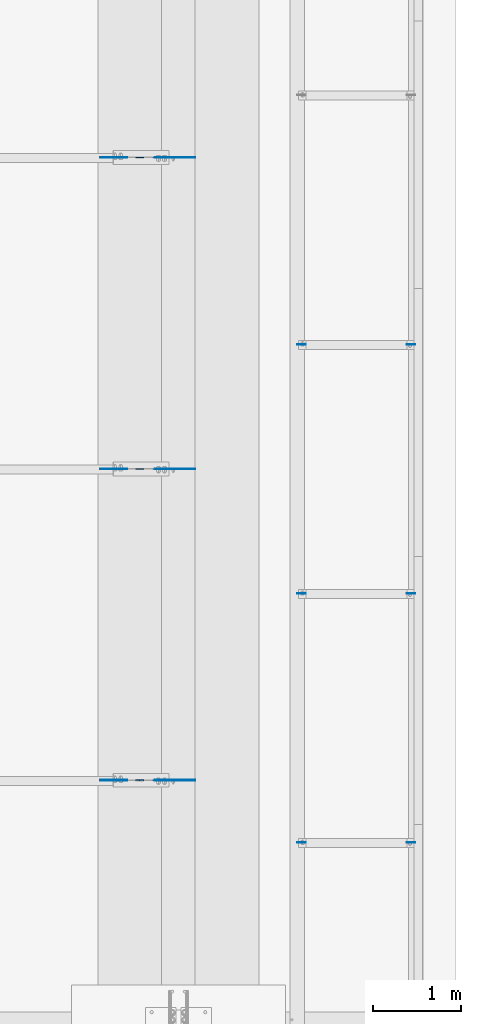
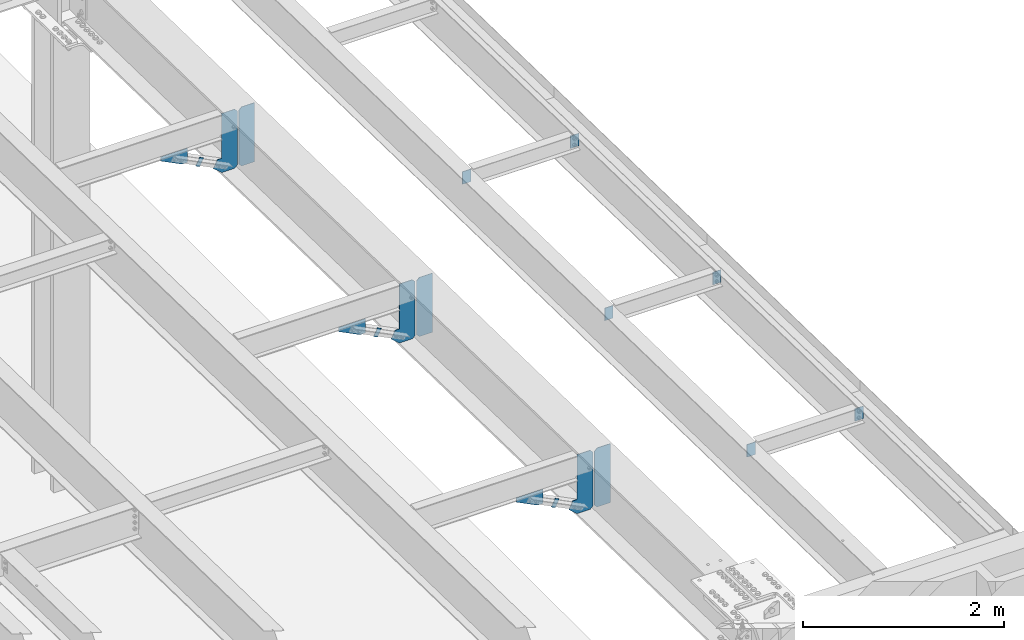
# One storey, part 1569 of 1763: 18 plates, 9 elements without a shape of their own.
"""IFC2X3 building model written with IfcOpenShell, lengths in millimetres."""

from ifc_helpers import new_model, si_unit, frame, origin_with_axes, place, context, subcontext, project, spatial, faceted_brep, material, type_object, element, aggregate, save


model = new_model("IFC2X3")

# Units and contexts
model_context = context("Model", 3, precision=1e-05, world=origin_with_axes())
body_context = subcontext(model_context, "Body", "Model", "MODEL_VIEW")
ifc_project = project(units=[si_unit("LENGTHUNIT", "METRE", prefix="MILLI"), si_unit("AREAUNIT", "SQUARE_METRE"), si_unit("VOLUMEUNIT", "CUBIC_METRE"), si_unit("MASSUNIT", "GRAM", prefix="KILO"), si_unit("TIMEUNIT", "SECOND"), si_unit("PLANEANGLEUNIT", "RADIAN"), si_unit("SOLIDANGLEUNIT", "STERADIAN"), si_unit("THERMODYNAMICTEMPERATUREUNIT", "DEGREE_CELSIUS"), si_unit("LUMINOUSINTENSITYUNIT", "LUMEN")], contexts=[model_context])

# Site, building, storey
site_placement = place(None, origin_with_axes())
site = spatial("IfcSite", under=ifc_project, at=site_placement, CompositionType="ELEMENT")
building_placement = place(site_placement, origin_with_axes())
building = spatial("IfcBuilding", under=site, at=building_placement, Name="Undefined", CompositionType="ELEMENT")
storey_placement = place(building_placement, origin_with_axes())
storey = spatial("IfcBuildingStorey", under=building, at=storey_placement, Name="Undefined", CompositionType="ELEMENT", Elevation=0.0)

# Assembly, plate
assembly_1_placement = place(storey_placement, origin_with_axes())
assembly_1 = element("IfcElementAssembly", 1, at=assembly_1_placement, inside=storey, Name="BEAM", AssemblyPlace="NOTDEFINED", PredefinedType="RIGID_FRAME")
ifc_material = material(Name="STEEL/A36")
plate_type_1 = type_object("IfcPlateType", PredefinedType="NOTDEFINED")
plate_1_placement = place(assembly_1_placement, frame((-24423.7585815478, -3079.7607496631, 11487.5607302139), z_axis=(-0.894427191199916, 0.0, 0.447213595099958), x_axis=(-0.447213595099945, 0.0, -0.894427191199922)))
plate_1 = element("IfcPlate", 2, at=plate_1_placement, type_object=plate_type_1, material=ifc_material, Name="PLATE", context=body_context, shape_type="Brep", body=[
    faceted_brep([(1.81898940354586e-12, -3.17500000000291, 0.0), (0.0, -3.17500000000291, 50.7999992370605), (0.0, 3.17500000000291, 50.7999992370605), (-1.81898940354586e-12, 3.17499999997381, 0.0), (101.599998474121, -3.17500000000291, 50.7999992370605), (101.599998474121, 3.17500000000291, 50.7999992370605), (101.599990844785, -3.17499999999927, -1.81898940354586e-11), (101.599990844785, 3.17499999999927, -1.81898940354586e-11)], [[[0, 1, 2, 3]], [[1, 4, 5, 2]], [[4, 6, 7, 5]], [[6, 0, 3, 7]], [[5, 7, 3, 2]], [[6, 4, 1, 0]]]),
])
aggregate(assembly_1, [plate_1])

assembly_2_placement = place(storey_placement, origin_with_axes())
assembly_2 = element("IfcElementAssembly", 3, at=assembly_2_placement, inside=storey, Name="BEAM", AssemblyPlace="NOTDEFINED", PredefinedType="RIGID_FRAME")
plate_2_placement = place(assembly_2_placement, frame((-24423.7585815478, -6623.04997034739, 11561.6364619885), z_axis=(-0.894427191199916, 0.0, 0.447213595099958), x_axis=(-0.447213595099945, 0.0, -0.894427191199922)))
plate_2 = element("IfcPlate", 4, at=plate_2_placement, type_object=plate_type_1, material=ifc_material, Name="PLATE", context=body_context, shape_type="Brep", body=[
    faceted_brep([(1.81898940354586e-12, -3.17500000000291, 0.0), (0.0, -3.17500000000291, 50.7999992370605), (0.0, 3.17500000000291, 50.7999992370605), (-1.81898940354586e-12, 3.17499999997381, 0.0), (101.599998474121, -3.17500000000291, 50.7999992370605), (101.599998474121, 3.17500000000291, 50.7999992370605), (101.599990844785, -3.17499999999927, -1.81898940354586e-11), (101.599990844785, 3.17499999999927, -1.81898940354586e-11)], [[[0, 1, 2, 3]], [[1, 4, 5, 2]], [[4, 6, 7, 5]], [[6, 0, 3, 7]], [[5, 7, 3, 2]], [[6, 4, 1, 0]]]),
])
aggregate(assembly_2, [plate_2])

assembly_3_placement = place(storey_placement, origin_with_axes())
assembly_3 = element("IfcElementAssembly", 5, at=assembly_3_placement, inside=storey, Name="BEAM", AssemblyPlace="NOTDEFINED", PredefinedType="RIGID_FRAME")
plate_3_placement = place(assembly_3_placement, frame((-24423.7585815478, -10166.3500000141, 11635.7124197349), z_axis=(-0.894427191199916, 0.0, 0.447213595099958), x_axis=(-0.447213595099945, 0.0, -0.894427191199922)))
plate_3 = element("IfcPlate", 6, at=plate_3_placement, type_object=plate_type_1, material=ifc_material, Name="PLATE", context=body_context, shape_type="Brep", body=[
    faceted_brep([(1.81898940354586e-12, -3.17500000000291, 0.0), (0.0, -3.17500000000291, 50.7999992370605), (0.0, 3.17500000000291, 50.7999992370605), (-1.81898940354586e-12, 3.17499999997381, 0.0), (101.599998474121, -3.17500000000291, 50.7999992370605), (101.599998474121, 3.17500000000291, 50.7999992370605), (101.599990844785, -3.17499999999927, -1.81898940354586e-11), (101.599990844785, 3.17499999999927, -1.81898940354586e-11)], [[[0, 1, 2, 3]], [[1, 4, 5, 2]], [[4, 6, 7, 5]], [[6, 0, 3, 7]], [[5, 7, 3, 2]], [[6, 4, 1, 0]]]),
])
aggregate(assembly_3, [plate_3])

assembly_4_placement = place(storey_placement, origin_with_axes())
assembly_4 = element("IfcElementAssembly", 7, at=assembly_4_placement, inside=storey, Name="BEAM", AssemblyPlace="NOTDEFINED", PredefinedType="RIGID_FRAME")
plate_type_2 = type_object("IfcPlateType", PredefinedType="NOTDEFINED")
plate_4_placement = place(assembly_4_placement, frame((-21333.8497736984, -5206.52374998633, 11995.1677041314), z_axis=(-1.0, 0.0, 0.0), x_axis=(0.0, 0.0, -1.0)))
plate_4 = element("IfcPlate", 8, at=plate_4_placement, type_object=plate_type_2, material=ifc_material, Name="PLATE", context=body_context, shape_type="Brep", body=[
    faceted_brep([(1.81898940354586e-12, -3.17500000000291, 0.0), (0.0, -3.17499999999927, 96.8375015258789), (0.0, 3.17499999999927, 96.8375015258789), (-1.81898940354586e-12, 3.17499999997381, 0.0), (152.399993896484, -3.17499999999927, 96.8375015258789), (152.399993896484, 3.17499999999927, 96.8375015258789), (152.399993896484, -3.17500000000291, 0.0), (152.399993896484, 3.17500000000291, 0.0)], [[[0, 1, 2, 3]], [[1, 4, 5, 2]], [[4, 6, 7, 5]], [[6, 0, 3, 7]], [[5, 7, 3, 2]], [[6, 4, 1, 0]]]),
])

assembly_5_placement = place(storey_placement, origin_with_axes())
assembly_5 = element("IfcElementAssembly", 9, at=assembly_5_placement, inside=storey, Name="BEAM", AssemblyPlace="NOTDEFINED", PredefinedType="RIGID_FRAME")
plate_5_placement = place(assembly_5_placement, frame((-22673.6997736984, -5206.52374998633, 11995.1677041314), z_axis=(1.0, 0.0, 0.0), x_axis=(0.0, 0.0, -1.0)))
plate_5 = element("IfcPlate", 10, at=plate_5_placement, type_object=plate_type_2, material=ifc_material, Name="PLATE", context=body_context, shape_type="Brep", body=[
    faceted_brep([(1.81898940354586e-12, -3.17500000000291, 0.0), (0.0, -3.17499999999927, 96.8375015258789), (0.0, 3.17499999999927, 96.8375015258789), (-1.81898940354586e-12, 3.17499999997381, 0.0), (152.399993896484, -3.17499999999927, 96.8375015258789), (152.399993896484, 3.17499999999927, 96.8375015258789), (152.399993896484, -3.17500000000291, 0.0), (152.399993896484, 3.17500000000291, 0.0)], [[[0, 1, 2, 3]], [[1, 4, 5, 2]], [[4, 6, 7, 5]], [[6, 0, 3, 7]], [[5, 7, 3, 2]], [[6, 4, 1, 0]]]),
])

# Plate
plate_6_placement = place(assembly_4_placement, frame((-21333.8497736984, -8041.16374999085, 12054.4284698343), z_axis=(-1.0, 0.0, 0.0), x_axis=(0.0, 0.0, -1.0)))
plate_6 = element("IfcPlate", 11, at=plate_6_placement, type_object=plate_type_2, material=ifc_material, Name="PLATE", context=body_context, shape_type="Brep", body=[
    faceted_brep([(1.81898940354586e-12, -3.17500000000291, 0.0), (0.0, -3.17499999999927, 96.8375015258789), (0.0, 3.17499999999927, 96.8375015258789), (-1.81898940354586e-12, 3.17499999997381, 0.0), (152.399993896484, -3.17499999999927, 96.8375015258789), (152.399993896484, 3.17499999999927, 96.8375015258789), (152.399993896484, -3.17500000000291, 0.0), (152.399993896484, 3.17500000000291, 0.0)], [[[0, 1, 2, 3]], [[1, 4, 5, 2]], [[4, 6, 7, 5]], [[6, 0, 3, 7]], [[5, 7, 3, 2]], [[6, 4, 1, 0]]]),
])

plate_7_placement = place(assembly_5_placement, frame((-22673.6997736984, -8041.16374999085, 12054.4284698343), z_axis=(1.0, 0.0, 0.0), x_axis=(0.0, 0.0, -1.0)))
plate_7 = element("IfcPlate", 12, at=plate_7_placement, type_object=plate_type_2, material=ifc_material, Name="PLATE", context=body_context, shape_type="Brep", body=[
    faceted_brep([(1.81898940354586e-12, -3.17500000000291, 0.0), (0.0, -3.17499999999927, 96.8375015258789), (0.0, 3.17499999999927, 96.8375015258789), (-1.81898940354586e-12, 3.17499999997381, 0.0), (152.399993896484, -3.17499999999927, 96.8375015258789), (152.399993896484, 3.17499999999927, 96.8375015258789), (152.399993896484, -3.17500000000291, 0.0), (152.399993896484, 3.17500000000291, 0.0)], [[[0, 1, 2, 3]], [[1, 4, 5, 2]], [[4, 6, 7, 5]], [[6, 0, 3, 7]], [[5, 7, 3, 2]], [[6, 4, 1, 0]]]),
])

plate_8_placement = place(assembly_4_placement, frame((-21333.8497736984, -10875.8037499954, 12113.6892355372), z_axis=(-1.0, 0.0, 0.0), x_axis=(0.0, 0.0, -1.0)))
plate_8 = element("IfcPlate", 13, at=plate_8_placement, type_object=plate_type_2, material=ifc_material, Name="PLATE", context=body_context, shape_type="Brep", body=[
    faceted_brep([(1.81898940354586e-12, -3.17500000000291, 0.0), (0.0, -3.17499999999927, 96.8375015258789), (0.0, 3.17499999999927, 96.8375015258789), (-1.81898940354586e-12, 3.17499999997381, 0.0), (152.399993896484, -3.17499999999927, 96.8375015258789), (152.399993896484, 3.17499999999927, 96.8375015258789), (152.399993896484, -3.17500000000291, 0.0), (152.399993896484, 3.17500000000291, 0.0)], [[[0, 1, 2, 3]], [[1, 4, 5, 2]], [[4, 6, 7, 5]], [[6, 0, 3, 7]], [[5, 7, 3, 2]], [[6, 4, 1, 0]]]),
])

aggregate(assembly_4, [plate_4, plate_6, plate_8])

plate_9_placement = place(assembly_5_placement, frame((-22673.6997736984, -10875.8037499954, 12113.6892355372), z_axis=(1.0, 0.0, 0.0), x_axis=(0.0, 0.0, -1.0)))
plate_9 = element("IfcPlate", 14, at=plate_9_placement, type_object=plate_type_2, material=ifc_material, Name="PLATE", context=body_context, shape_type="Brep", body=[
    faceted_brep([(1.81898940354586e-12, -3.17500000000291, 0.0), (0.0, -3.17499999999927, 96.8375015258789), (0.0, 3.17499999999927, 96.8375015258789), (-1.81898940354586e-12, 3.17499999997381, 0.0), (152.399993896484, -3.17499999999927, 96.8375015258789), (152.399993896484, 3.17499999999927, 96.8375015258789), (152.399993896484, -3.17500000000291, 0.0), (152.399993896484, 3.17500000000291, 0.0)], [[[0, 1, 2, 3]], [[1, 4, 5, 2]], [[4, 6, 7, 5]], [[6, 0, 3, 7]], [[5, 7, 3, 2]], [[6, 4, 1, 0]]]),
])

aggregate(assembly_5, [plate_5, plate_7, plate_9])

# Assembly, plates
assembly_6_placement = place(storey_placement, origin_with_axes())
assembly_6 = element("IfcElementAssembly", 15, at=assembly_6_placement, inside=storey, Name="BEAM", AssemblyPlace="NOTDEFINED", PredefinedType="RIGID_FRAME")
plate_type_3 = type_object("IfcPlateType", PredefinedType="NOTDEFINED")
plate_10_placement = place(assembly_6_placement, frame((-24019.5997736984, -3079.76074969909, 11236.4175994145), z_axis=(0.0, 0.0, 1.0), x_axis=(1.0, 0.0, 0.0)))
plate_10 = element("IfcPlate", 16, at=plate_10_placement, type_object=plate_type_3, material=ifc_material, Name="PLATE", context=body_context, shape_type="Brep", body=[
    faceted_brep([(0.0, -3.17500000000291, 31.75), (0.0, -3.17499999999927, 686.812194824219), (0.0, 3.17499999999927, 686.812194824219), (0.0, 3.17500000000291, 31.75), (31.75, -3.17499999999927, 718.562194824219), (31.75, 3.17499999999927, 718.562194824219), (182.5625, -3.17499999999927, 718.562194824219), (182.5625, 3.17499999999927, 718.562194824219), (182.5625, -3.17500000000291, 0.0), (182.5625, 3.17500000000291, 0.0), (31.7499999999036, -3.17499999997381, 9.42916855706244e-11), (31.7499999998854, 3.17500000000291, 9.42916855706244e-11)], [[[0, 1, 2, 3]], [[1, 4, 5, 2]], [[4, 6, 7, 5]], [[6, 8, 9, 7]], [[8, 10, 11, 9]], [[10, 0, 3, 11]], [[5, 7, 9, 11, 3, 2]], [[10, 8, 6, 4, 1, 0]]]),
])
plate_11_placement = place(assembly_6_placement, frame((-24019.5997736984, -6623.04997038337, 11310.4933311891), z_axis=(0.0, 0.0, 1.0), x_axis=(1.0, 0.0, 0.0)))
plate_11 = element("IfcPlate", 17, at=plate_11_placement, type_object=plate_type_3, material=ifc_material, Name="PLATE", context=body_context, shape_type="Brep", body=[
    faceted_brep([(0.0, -3.17500000000291, 31.75), (0.0, -3.17499999999927, 686.812194824219), (0.0, 3.17499999999927, 686.812194824219), (0.0, 3.17500000000291, 31.75), (31.75, -3.17499999999927, 718.562194824219), (31.75, 3.17499999999927, 718.562194824219), (182.5625, -3.17499999999927, 718.562194824219), (182.5625, 3.17499999999927, 718.562194824219), (182.5625, -3.17500000000291, 0.0), (182.5625, 3.17500000000291, 0.0), (31.7499999999036, -3.17499999997381, 9.42916855706244e-11), (31.7499999998854, 3.17500000000291, 9.42916855706244e-11)], [[[0, 1, 2, 3]], [[1, 4, 5, 2]], [[4, 6, 7, 5]], [[6, 8, 9, 7]], [[8, 10, 11, 9]], [[10, 0, 3, 11]], [[5, 7, 9, 11, 3, 2]], [[10, 8, 6, 4, 1, 0]]]),
])
plate_12_placement = place(assembly_6_placement, frame((-24019.5997736984, -10166.3500000501, 11384.5692889355), z_axis=(0.0, 0.0, 1.0), x_axis=(1.0, 0.0, 0.0)))
plate_12 = element("IfcPlate", 18, at=plate_12_placement, type_object=plate_type_3, material=ifc_material, Name="PLATE", context=body_context, shape_type="Brep", body=[
    faceted_brep([(0.0, -3.17500000000291, 31.75), (0.0, -3.17499999999927, 686.812194824219), (0.0, 3.17499999999927, 686.812194824219), (0.0, 3.17500000000291, 31.75), (31.75, -3.17499999999927, 718.562194824219), (31.75, 3.17499999999927, 718.562194824219), (182.5625, -3.17499999999927, 718.562194824219), (182.5625, 3.17499999999927, 718.562194824219), (182.5625, -3.17500000000291, 0.0), (182.5625, 3.17500000000291, 0.0), (31.7499999999036, -3.17499999997381, 9.42916855706244e-11), (31.7499999998854, 3.17500000000291, 9.42916855706244e-11)], [[[0, 1, 2, 3]], [[1, 4, 5, 2]], [[4, 6, 7, 5]], [[6, 8, 9, 7]], [[8, 10, 11, 9]], [[10, 0, 3, 11]], [[5, 7, 9, 11, 3, 2]], [[10, 8, 6, 4, 1, 0]]]),
])
plate_type_4 = type_object("IfcPlateType", PredefinedType="NOTDEFINED")
plate_13_placement = place(assembly_6_placement, frame((-24036.0747736984, -3079.76074969909, 11236.4175994145), z_axis=(0.0, 0.0, 1.0), x_axis=(-1.0, 0.0, 0.0)))
plate_13 = element("IfcPlate", 19, at=plate_13_placement, type_object=plate_type_4, material=ifc_material, Name="PLATE", context=body_context, shape_type="Brep", body=[
    faceted_brep([(0.0, -3.17500000000291, 31.75), (0.0, -3.17499999999927, 686.812255859375), (0.0, 3.17499999999927, 686.812255859375), (0.0, 3.17500000000291, 31.75), (31.75, -3.17499999999927, 718.562255859375), (31.75, 3.17499999999927, 718.562255859375), (182.261993408203, -3.17499999999927, 718.562255859375), (182.261993408203, 3.17499999999927, 718.562255859375), (182.261993408203, -3.17499999999927, 172.454345703125), (182.261993408203, 3.17499999999927, 172.454345703125), (230.306228637695, -3.17499999999927, 172.454345703125), (230.306228637695, 3.17499999999927, 172.454345703125), (275.743133544922, -3.17499999999927, 81.5805358886719), (275.743133544922, 3.17499999999927, 81.5805358886719), (182.261993408203, -3.17499999999927, 0.0), (182.261993408203, 3.17499999999927, 0.0), (31.7499999999036, -3.17499999997381, 9.42916855706244e-11), (31.7499999998854, 3.17500000000291, 9.42916855706244e-11)], [[[0, 1, 2, 3]], [[1, 4, 5, 2]], [[4, 6, 7, 5]], [[6, 8, 9, 7]], [[8, 10, 11, 9]], [[10, 12, 13, 11]], [[12, 14, 15, 13]], [[14, 16, 17, 15]], [[16, 0, 3, 17]], [[5, 7, 9, 11, 13, 15, 17, 3, 2]], [[16, 14, 12, 10, 8, 6, 4, 1, 0]]]),
])
plate_14_placement = place(assembly_6_placement, frame((-24036.0747736984, -6623.04997038337, 11310.4933311891), z_axis=(0.0, 0.0, 1.0), x_axis=(-1.0, 0.0, 0.0)))
plate_14 = element("IfcPlate", 20, at=plate_14_placement, type_object=plate_type_4, material=ifc_material, Name="PLATE", context=body_context, shape_type="Brep", body=[
    faceted_brep([(0.0, -3.17500000000291, 31.75), (0.0, -3.17499999999927, 686.812255859375), (0.0, 3.17499999999927, 686.812255859375), (0.0, 3.17500000000291, 31.75), (31.75, -3.17499999999927, 718.562255859375), (31.75, 3.17499999999927, 718.562255859375), (182.261993408203, -3.17499999999927, 718.562255859375), (182.261993408203, 3.17499999999927, 718.562255859375), (182.261993408203, -3.17499999999927, 172.454345703125), (182.261993408203, 3.17499999999927, 172.454345703125), (230.306228637695, -3.17499999999927, 172.454345703125), (230.306228637695, 3.17499999999927, 172.454345703125), (275.743133544922, -3.17499999999927, 81.5805358886719), (275.743133544922, 3.17499999999927, 81.5805358886719), (182.261993408203, -3.17499999999927, 0.0), (182.261993408203, 3.17499999999927, 0.0), (31.7499999999036, -3.17499999997381, 9.42916855706244e-11), (31.7499999998854, 3.17500000000291, 9.42916855706244e-11)], [[[0, 1, 2, 3]], [[1, 4, 5, 2]], [[4, 6, 7, 5]], [[6, 8, 9, 7]], [[8, 10, 11, 9]], [[10, 12, 13, 11]], [[12, 14, 15, 13]], [[14, 16, 17, 15]], [[16, 0, 3, 17]], [[5, 7, 9, 11, 13, 15, 17, 3, 2]], [[16, 14, 12, 10, 8, 6, 4, 1, 0]]]),
])
plate_15_placement = place(assembly_6_placement, frame((-24036.0747736984, -10166.3500000501, 11384.5692889355), z_axis=(0.0, 0.0, 1.0), x_axis=(-1.0, 0.0, 0.0)))
plate_15 = element("IfcPlate", 21, at=plate_15_placement, type_object=plate_type_4, material=ifc_material, Name="PLATE", context=body_context, shape_type="Brep", body=[
    faceted_brep([(0.0, -3.17500000000291, 31.75), (0.0, -3.17499999999927, 686.812255859375), (0.0, 3.17499999999927, 686.812255859375), (0.0, 3.17500000000291, 31.75), (31.75, -3.17499999999927, 718.562255859375), (31.75, 3.17499999999927, 718.562255859375), (182.261993408203, -3.17499999999927, 718.562255859375), (182.261993408203, 3.17499999999927, 718.562255859375), (182.261993408203, -3.17499999999927, 172.454345703125), (182.261993408203, 3.17499999999927, 172.454345703125), (230.306228637695, -3.17499999999927, 172.454345703125), (230.306228637695, 3.17499999999927, 172.454345703125), (275.743133544922, -3.17499999999927, 81.5805358886719), (275.743133544922, 3.17499999999927, 81.5805358886719), (182.261993408203, -3.17499999999927, 0.0), (182.261993408203, 3.17499999999927, 0.0), (31.7499999999036, -3.17499999997381, 9.42916855706244e-11), (31.7499999998854, 3.17500000000291, 9.42916855706244e-11)], [[[0, 1, 2, 3]], [[1, 4, 5, 2]], [[4, 6, 7, 5]], [[6, 8, 9, 7]], [[8, 10, 11, 9]], [[10, 12, 13, 11]], [[12, 14, 15, 13]], [[14, 16, 17, 15]], [[16, 0, 3, 17]], [[5, 7, 9, 11, 13, 15, 17, 3, 2]], [[16, 14, 12, 10, 8, 6, 4, 1, 0]]]),
])
aggregate(assembly_6, [plate_10, plate_13, plate_11, plate_14, plate_12, plate_15])

# Assembly, plate
assembly_7_placement = place(storey_placement, origin_with_axes())
assembly_7 = element("IfcElementAssembly", 22, at=assembly_7_placement, inside=storey, Name="BEAM", AssemblyPlace="NOTDEFINED", PredefinedType="RIGID_FRAME")
plate_type_5 = type_object("IfcPlateType", PredefinedType="NOTDEFINED")
plate_16_placement = place(assembly_7_placement, frame((-24610.7958721203, -3079.76074964962, 11671.3223545926), z_axis=(-1.0, 0.0, 0.0), x_axis=(0.0, 0.0, -1.0)))
plate_16 = element("IfcPlate", 23, at=plate_16_placement, type_object=plate_type_5, material=ifc_material, Name="PLATE", context=body_context, shape_type="Brep", body=[
    faceted_brep([(1.81898940354586e-12, -3.17500000000291, 0.0), (0.0, -3.17499999999927, 306.070465087891), (0.0, 3.17499999999927, 306.070465087891), (-1.81898940354586e-12, 3.17499999997381, 0.0), (50.7999992370605, -3.17499999999927, 306.070465087891), (50.7999992370605, 3.17499999999927, 306.070465087891), (172.922760009766, -3.17499999999927, 61.8249359130859), (172.922760009766, 3.17499999999927, 61.8249359130859), (172.922760009766, -3.17499999999927, 0.0), (172.922760009766, 3.17499999999927, 0.0)], [[[0, 1, 2, 3]], [[1, 4, 5, 2]], [[4, 6, 7, 5]], [[6, 8, 9, 7]], [[8, 0, 3, 9]], [[5, 7, 9, 3, 2]], [[8, 6, 4, 1, 0]]]),
])
aggregate(assembly_7, [plate_16])

assembly_8_placement = place(storey_placement, origin_with_axes())
assembly_8 = element("IfcElementAssembly", 24, at=assembly_8_placement, inside=storey, Name="BEAM", AssemblyPlace="NOTDEFINED", PredefinedType="RIGID_FRAME")
plate_17_placement = place(assembly_8_placement, frame((-24610.7958721203, -6623.04997033391, 11745.3980863672), z_axis=(-1.0, 0.0, 0.0), x_axis=(0.0, 0.0, -1.0)))
plate_17 = element("IfcPlate", 25, at=plate_17_placement, type_object=plate_type_5, material=ifc_material, Name="PLATE", context=body_context, shape_type="Brep", body=[
    faceted_brep([(1.81898940354586e-12, -3.17500000000291, 0.0), (0.0, -3.17499999999927, 306.070465087891), (0.0, 3.17499999999927, 306.070465087891), (-1.81898940354586e-12, 3.17499999997381, 0.0), (50.7999992370605, -3.17499999999927, 306.070465087891), (50.7999992370605, 3.17499999999927, 306.070465087891), (172.922760009766, -3.17499999999927, 61.8249359130859), (172.922760009766, 3.17499999999927, 61.8249359130859), (172.922760009766, -3.17499999999927, 0.0), (172.922760009766, 3.17499999999927, 0.0)], [[[0, 1, 2, 3]], [[1, 4, 5, 2]], [[4, 6, 7, 5]], [[6, 8, 9, 7]], [[8, 0, 3, 9]], [[5, 7, 9, 3, 2]], [[8, 6, 4, 1, 0]]]),
])
aggregate(assembly_8, [plate_17])

assembly_9_placement = place(storey_placement, origin_with_axes())
assembly_9 = element("IfcElementAssembly", 26, at=assembly_9_placement, inside=storey, Name="BEAM", AssemblyPlace="NOTDEFINED", PredefinedType="RIGID_FRAME")
plate_18_placement = place(assembly_9_placement, frame((-24610.7958721203, -10166.3500000006, 11819.4740441136), z_axis=(-1.0, 0.0, 0.0), x_axis=(0.0, 0.0, -1.0)))
plate_18 = element("IfcPlate", 27, at=plate_18_placement, type_object=plate_type_5, material=ifc_material, Name="PLATE", context=body_context, shape_type="Brep", body=[
    faceted_brep([(1.81898940354586e-12, -3.17500000000291, 0.0), (0.0, -3.17499999999927, 306.070465087891), (0.0, 3.17499999999927, 306.070465087891), (-1.81898940354586e-12, 3.17499999997381, 0.0), (50.7999992370605, -3.17499999999927, 306.070465087891), (50.7999992370605, 3.17499999999927, 306.070465087891), (172.922760009766, -3.17499999999927, 61.8249359130859), (172.922760009766, 3.17499999999927, 61.8249359130859), (172.922760009766, -3.17499999999927, 0.0), (172.922760009766, 3.17499999999927, 0.0)], [[[0, 1, 2, 3]], [[1, 4, 5, 2]], [[4, 6, 7, 5]], [[6, 8, 9, 7]], [[8, 0, 3, 9]], [[5, 7, 9, 3, 2]], [[8, 6, 4, 1, 0]]]),
])
aggregate(assembly_9, [plate_18])

save(model, "model.ifc")
